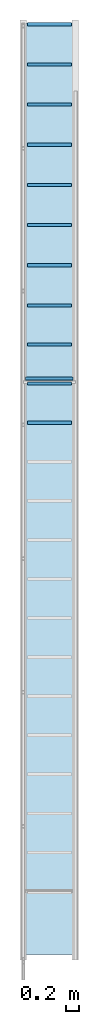
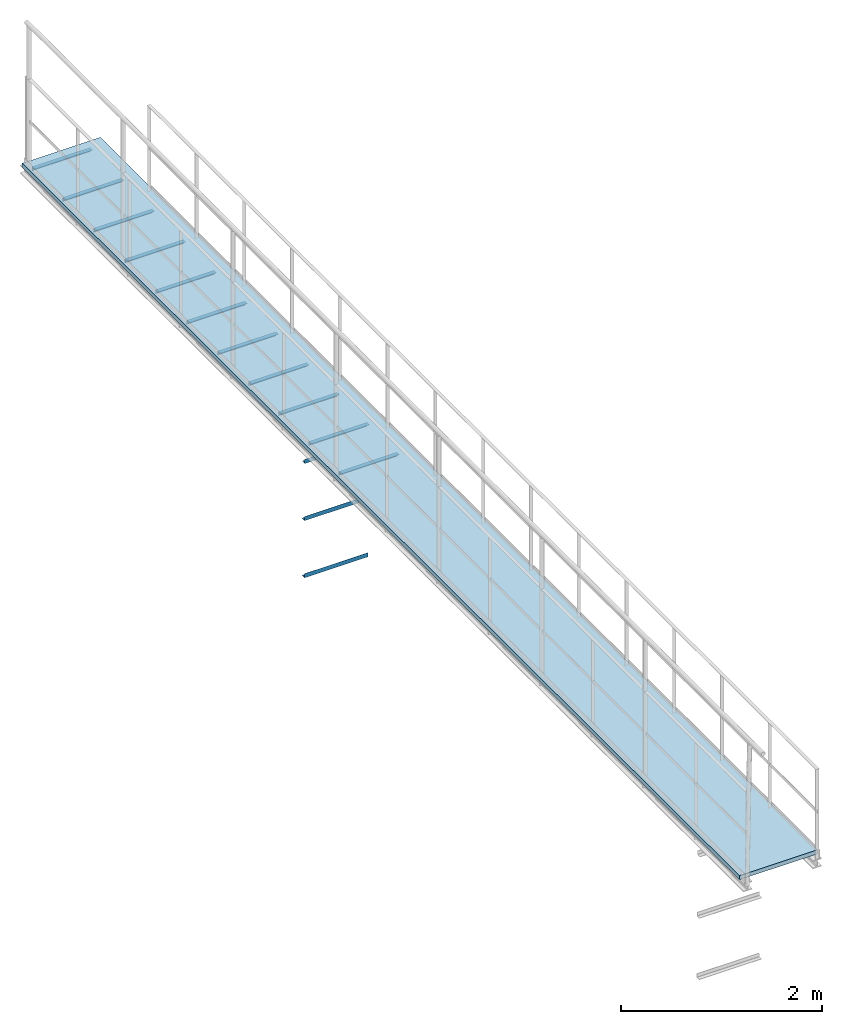
# One storey, part 5 of 6: 11 beams, 3 members, 1 slab.
"""IFC2X3 building model written with IfcOpenShell, lengths in metres."""

from ifc_helpers import new_model, entity, si_unit, converted_unit, derived_unit, direction, frame, frame_2d, origin, place, context, subcontext, project, spatial, polyline, circle_curve, parameter, trimmed, segment, composite_curve, rectangle, outline, extrude, source, transform, mapped, material, layer, layer_set, layer_usage, type_object, type_shapes, element, save


model = new_model("IFC2X3")

# Units and contexts
model_context = context("Model", 3, precision=1e-05, world=origin(), true_north=direction((6.123233995736766e-17, 1.0)))
body_context = subcontext(model_context, "Body", "Model", "MODEL_VIEW")
ifc_project = project(units=[si_unit("LENGTHUNIT", "METRE"), converted_unit("PLANEANGLEUNIT", "DEGREE", entity("IfcPlaneAngleMeasure", 0.017453292519943278), si_unit("PLANEANGLEUNIT", "RADIAN"), dimensions=[0, 0, 0, 0, 0, 0, 0]), si_unit("AREAUNIT", "SQUARE_METRE"), derived_unit("THERMALTRANSMITTANCEUNIT", [(si_unit("MASSUNIT", "GRAM", prefix="KILO"), 1), (si_unit("THERMODYNAMICTEMPERATUREUNIT", "KELVIN"), -1), (si_unit("TIMEUNIT", "SECOND"), -3)])], contexts=[model_context])

# Site, building, storey
site_placement = place(None, origin())
site = spatial("IfcSite", under=ifc_project, at=site_placement, CompositionType="ELEMENT")
building_placement = place(site_placement, origin())
building = spatial("IfcBuilding", under=site, at=building_placement, CompositionType="ELEMENT")
storey_placement = place(building_placement, frame((0.0, 0.0, 8.8)))
storey = spatial("IfcBuildingStorey", under=building, at=storey_placement, Name="Piso 2.3", CompositionType="ELEMENT", Elevation=8.8)

# Beams
ifc_material_1 = material(Name="Metal - Steel - 345 MPa")
beam_type = type_object("IfcBeamType", Name="L-Angles:CAE50x5", PredefinedType="BEAM")
beam_1_placement = place(storey_placement, frame((3.7066971351921265, 3.8935222324362275, 0.0)))
element("IfcBeam", 1, at=beam_1_placement, inside=storey, type_object=beam_type, material=ifc_material_1, Name="L-Angles:CAE50x5", ObjectType="L-Angles:CAE50x5", context=body_context, shape_type="SweptSolid", body=[
    extrude(outline(composite_curve([segment(polyline([(-0.033571428571429786, -0.01642857142857166), (0.016428571428569683, -0.01642857142857166)]), True, "CONTINUOUS"), segment(polyline([(0.016428571428569683, -0.0164285714285722), (0.016428571428570224, 0.03357142857143051)]), True, "CONTINUOUS"), segment(trimmed(circle_curve(frame_2d((0.01642857142857017, 0.02857142857143002), x_axis=(0.0, 1.0)), 0.004999999999999386), [parameter(0.0)], [parameter(90.0000000000187)], True, "PARAMETER"), True, "CONTINUOUS"), segment(polyline([(0.011428571428571305, 0.02857142857142953), (0.011428571428570927, -0.006428571428572257)]), True, "CONTINUOUS"), segment(trimmed(circle_curve(frame_2d((0.00642857142857098, -0.006428571428572743), x_axis=(1.0, 0.0)), 0.004999999999999392), [parameter(269.9999999999813)], [parameter(0.0)], True, "PARAMETER"), False, "CONTINUOUS"), segment(polyline([(0.006428571428569843, -0.011428571428572148), (-0.028571428571430864, -0.011428571428571229)]), True, "CONTINUOUS"), segment(trimmed(circle_curve(frame_2d((-0.028571428571429833, -0.016428571428571716), x_axis=(0.0, 1.0)), 0.0049999999999998075), [parameter(0.0)], [parameter(90.00000000000009)], True, "PARAMETER"), True, "CONTINUOUS")], self_intersect=False)), frame((0.06300000000002287, -0.002428571428571418, -0.002428571428575208), z_axis=(1.0, 0.0, 0.0), x_axis=(0.0, 0.0, 1.0)), (0.0, 0.0, 1.0), 0.6740000000000007),
])
beam_2_placement = place(storey_placement, frame((3.7066971351921265, 4.493522232436228, 0.0)))
element("IfcBeam", 2, at=beam_2_placement, inside=storey, type_object=beam_type, material=ifc_material_1, Name="L-Angles:CAE50x5", ObjectType="L-Angles:CAE50x5", context=body_context, shape_type="SweptSolid", body=[
    extrude(outline(composite_curve([segment(polyline([(-0.033571428571429786, -0.01642857142857112), (0.016428571428569683, -0.01642857142857112)]), True, "CONTINUOUS"), segment(polyline([(0.016428571428569683, -0.01642857142857166), (0.016428571428570224, 0.03357142857143105)]), True, "CONTINUOUS"), segment(trimmed(circle_curve(frame_2d((0.01642857142857017, 0.028571428571430562), x_axis=(0.0, 1.0)), 0.004999999999999386), [parameter(0.0)], [parameter(90.0000000000187)], True, "PARAMETER"), True, "CONTINUOUS"), segment(polyline([(0.011428571428571305, 0.028571428571430073), (0.011428571428570927, -0.006428571428571715)]), True, "CONTINUOUS"), segment(trimmed(circle_curve(frame_2d((0.00642857142857098, -0.006428571428572201), x_axis=(1.0, 0.0)), 0.004999999999999392), [parameter(269.9999999999813)], [parameter(0.0)], True, "PARAMETER"), False, "CONTINUOUS"), segment(polyline([(0.006428571428569843, -0.011428571428571607), (-0.028571428571430864, -0.011428571428570686)]), True, "CONTINUOUS"), segment(trimmed(circle_curve(frame_2d((-0.028571428571429833, -0.016428571428571175), x_axis=(0.0, 1.0)), 0.0049999999999998075), [parameter(0.0)], [parameter(90.00000000000009)], True, "PARAMETER"), True, "CONTINUOUS")], self_intersect=False)), frame((0.06300000000002301, -0.0024285714285708763, -0.002428571428575208), z_axis=(1.0, 0.0, 0.0), x_axis=(0.0, 0.0, 1.0)), (0.0, 0.0, 1.0), 0.6740000000000007),
])
beam_3_placement = place(storey_placement, frame((3.7066971351921265, 5.093522232436227, 0.0)))
element("IfcBeam", 3, at=beam_3_placement, inside=storey, type_object=beam_type, material=ifc_material_1, Name="L-Angles:CAE50x5", ObjectType="L-Angles:CAE50x5", context=body_context, shape_type="SweptSolid", body=[
    extrude(outline(composite_curve([segment(polyline([(-0.033571428571429605, -0.016428571428572025), (0.01642857142856986, -0.016428571428572025)]), True, "CONTINUOUS"), segment(polyline([(0.01642857142856986, -0.016428571428572025), (0.01642857142856986, 0.033571428571429605)]), True, "CONTINUOUS"), segment(trimmed(circle_curve(frame_2d((0.01642857142856986, 0.02857142857143182), x_axis=(0.0, 1.0)), 0.004999999999999224), [parameter(0.0)], [parameter(90.00000000002491)], True, "PARAMETER"), True, "CONTINUOUS"), segment(polyline([(0.011428571428570997, 0.02857142857143074), (0.011428571428570997, -0.00642857142857105)]), True, "CONTINUOUS"), segment(trimmed(circle_curve(frame_2d((0.006428571428571049, -0.006428571428573215), x_axis=(1.0, 0.0)), 0.004999999999999229), [parameter(269.9999999999751)], [parameter(0.0)], True, "PARAMETER"), False, "CONTINUOUS"), segment(polyline([(0.006428571428569967, -0.011428571428572079), (-0.02857142857143074, -0.011428571428572079)]), True, "CONTINUOUS"), segment(trimmed(circle_curve(frame_2d((-0.028571428571429656, -0.016428571428572025), x_axis=(0.0, 1.0)), 0.004999999999999669), [parameter(0.0)], [parameter(90.00000000000009)], True, "PARAMETER"), True, "CONTINUOUS")], self_intersect=False)), frame((0.06300000000002313, -0.002428571428571959, -0.002428571428575208), z_axis=(1.0, 0.0, 0.0), x_axis=(0.0, 0.0, 1.0)), (0.0, 0.0, 1.0), 0.6740000000000007),
])
beam_4_placement = place(storey_placement, frame((3.7066971351921265, 5.693522232436227, 0.0)))
element("IfcBeam", 4, at=beam_4_placement, inside=storey, type_object=beam_type, material=ifc_material_1, Name="L-Angles:CAE50x5", ObjectType="L-Angles:CAE50x5", context=body_context, shape_type="SweptSolid", body=[
    extrude(outline(composite_curve([segment(polyline([(-0.033571428571429605, -0.016428571428572025), (0.01642857142856986, -0.016428571428572025)]), True, "CONTINUOUS"), segment(polyline([(0.01642857142856986, -0.016428571428572025), (0.01642857142856986, 0.033571428571429605)]), True, "CONTINUOUS"), segment(trimmed(circle_curve(frame_2d((0.01642857142856986, 0.02857142857143182), x_axis=(0.0, 1.0)), 0.004999999999999224), [parameter(0.0)], [parameter(90.00000000002491)], True, "PARAMETER"), True, "CONTINUOUS"), segment(polyline([(0.011428571428570997, 0.02857142857143074), (0.011428571428570997, -0.00642857142857105)]), True, "CONTINUOUS"), segment(trimmed(circle_curve(frame_2d((0.006428571428571049, -0.006428571428573215), x_axis=(1.0, 0.0)), 0.004999999999999229), [parameter(269.9999999999751)], [parameter(0.0)], True, "PARAMETER"), False, "CONTINUOUS"), segment(polyline([(0.006428571428569967, -0.011428571428572079), (-0.02857142857143074, -0.011428571428572079)]), True, "CONTINUOUS"), segment(trimmed(circle_curve(frame_2d((-0.028571428571429656, -0.016428571428572025), x_axis=(0.0, 1.0)), 0.004999999999999669), [parameter(0.0)], [parameter(90.00000000000009)], True, "PARAMETER"), True, "CONTINUOUS")], self_intersect=False)), frame((0.06300000000002327, -0.002428571428571959, -0.002428571428575208), z_axis=(1.0, 0.0, 0.0), x_axis=(0.0, 0.0, 1.0)), (0.0, 0.0, 1.0), 0.6740000000000007),
])
beam_5_placement = place(storey_placement, frame((3.7066971351921336, 10.011170093366113, 0.0)))
element("IfcBeam", 5, at=beam_5_placement, inside=storey, type_object=beam_type, material=ifc_material_1, Name="L-Angles:CAE50x5", ObjectType="L-Angles:CAE50x5", context=body_context, shape_type="SweptSolid", body=[
    extrude(outline(composite_curve([segment(polyline([(-0.033571428571429605, -0.016428571428572025), (0.01642857142856986, -0.016428571428572025)]), True, "CONTINUOUS"), segment(polyline([(0.01642857142856986, -0.016428571428572025), (0.01642857142856986, 0.033571428571429605)]), True, "CONTINUOUS"), segment(trimmed(circle_curve(frame_2d((0.016428571428573107, 0.02857142857142641), x_axis=(0.0, 1.0)), 0.00500000000000243), [parameter(0.0)], [parameter(89.99999999995046)], True, "PARAMETER"), True, "CONTINUOUS"), segment(polyline([(0.011428571428570997, 0.028571428571428574), (0.011428571428570997, -0.0064285714285742986)]), True, "CONTINUOUS"), segment(trimmed(circle_curve(frame_2d((0.006428571428567802, -0.006428571428569967), x_axis=(1.0, 0.0)), 0.005000000000002431), [parameter(270.0000000000495)], [parameter(0.0)], True, "PARAMETER"), False, "CONTINUOUS"), segment(polyline([(0.006428571428569967, -0.011428571428573162), (-0.02857142857143074, -0.011428571428573162)]), True, "CONTINUOUS"), segment(trimmed(circle_curve(frame_2d((-0.02857142857142749, -0.016428571428574193), x_axis=(0.0, 1.0)), 0.005000000000002427), [parameter(0.0)], [parameter(89.99999999995046)], True, "PARAMETER"), True, "CONTINUOUS")], self_intersect=False)), frame((0.06300000000002329, -0.002428571428575208, -0.002428571428575208), z_axis=(1.0, 0.0, 0.0), x_axis=(0.0, 0.0, 1.0)), (0.0, 0.0, 1.0), 0.6740000000000002),
])
beam_6_placement = place(storey_placement, frame((3.7066971351921265, 6.310329069711925, 0.0)))
element("IfcBeam", 6, at=beam_6_placement, inside=storey, type_object=beam_type, material=ifc_material_1, Name="L-Angles:CAE50x5", ObjectType="L-Angles:CAE50x5", context=body_context, shape_type="SweptSolid", body=[
    extrude(outline(composite_curve([segment(polyline([(-0.033571428571429605, -0.016428571428572025), (0.01642857142856986, -0.016428571428572025)]), True, "CONTINUOUS"), segment(polyline([(0.01642857142856986, -0.016428571428572025), (0.01642857142856986, 0.033571428571429605)]), True, "CONTINUOUS"), segment(trimmed(circle_curve(frame_2d((0.01642857142856986, 0.02857142857143182), x_axis=(0.0, 1.0)), 0.004999999999999224), [parameter(0.0)], [parameter(90.00000000002491)], True, "PARAMETER"), True, "CONTINUOUS"), segment(polyline([(0.011428571428570997, 0.02857142857143074), (0.011428571428570997, -0.00642857142857105)]), True, "CONTINUOUS"), segment(trimmed(circle_curve(frame_2d((0.006428571428571049, -0.006428571428573215), x_axis=(1.0, 0.0)), 0.004999999999999229), [parameter(269.9999999999751)], [parameter(0.0)], True, "PARAMETER"), False, "CONTINUOUS"), segment(polyline([(0.006428571428569967, -0.011428571428572079), (-0.02857142857143074, -0.011428571428572079)]), True, "CONTINUOUS"), segment(trimmed(circle_curve(frame_2d((-0.028571428571429656, -0.016428571428572025), x_axis=(0.0, 1.0)), 0.004999999999999669), [parameter(0.0)], [parameter(90.00000000000009)], True, "PARAMETER"), True, "CONTINUOUS")], self_intersect=False)), frame((0.06300000000002282, -0.002428571428571959, -0.002428571428575208), z_axis=(1.0, 0.0, 0.0), x_axis=(0.0, 0.0, 1.0)), (0.0, 0.0, 1.0), 0.6740000000000007),
])
beam_7_placement = place(storey_placement, frame((3.7066971351921265, 6.9271359069876235, 0.0)))
element("IfcBeam", 7, at=beam_7_placement, inside=storey, type_object=beam_type, material=ifc_material_1, Name="L-Angles:CAE50x5", ObjectType="L-Angles:CAE50x5", context=body_context, shape_type="SweptSolid", body=[
    extrude(outline(composite_curve([segment(polyline([(-0.033571428571429605, -0.016428571428572025), (0.01642857142856986, -0.016428571428572025)]), True, "CONTINUOUS"), segment(polyline([(0.01642857142856986, -0.016428571428572025), (0.01642857142856986, 0.033571428571429605)]), True, "CONTINUOUS"), segment(trimmed(circle_curve(frame_2d((0.01642857142856986, 0.02857142857143182), x_axis=(0.0, 1.0)), 0.004999999999999224), [parameter(0.0)], [parameter(90.00000000002491)], True, "PARAMETER"), True, "CONTINUOUS"), segment(polyline([(0.011428571428570997, 0.02857142857143074), (0.011428571428570997, -0.00642857142857105)]), True, "CONTINUOUS"), segment(trimmed(circle_curve(frame_2d((0.006428571428571049, -0.006428571428573215), x_axis=(1.0, 0.0)), 0.004999999999999229), [parameter(269.9999999999751)], [parameter(0.0)], True, "PARAMETER"), False, "CONTINUOUS"), segment(polyline([(0.006428571428569967, -0.011428571428572079), (-0.02857142857143074, -0.011428571428572079)]), True, "CONTINUOUS"), segment(trimmed(circle_curve(frame_2d((-0.028571428571429656, -0.016428571428572025), x_axis=(0.0, 1.0)), 0.004999999999999669), [parameter(0.0)], [parameter(90.00000000000009)], True, "PARAMETER"), True, "CONTINUOUS")], self_intersect=False)), frame((0.06300000000002288, -0.002428571428571959, -0.002428571428575208), z_axis=(1.0, 0.0, 0.0), x_axis=(0.0, 0.0, 1.0)), (0.0, 0.0, 1.0), 0.6740000000000007),
])
beam_8_placement = place(storey_placement, frame((3.7066971351921265, 7.543942744263322, 0.0)))
element("IfcBeam", 8, at=beam_8_placement, inside=storey, type_object=beam_type, material=ifc_material_1, Name="L-Angles:CAE50x5", ObjectType="L-Angles:CAE50x5", context=body_context, shape_type="SweptSolid", body=[
    extrude(outline(composite_curve([segment(polyline([(-0.033571428571429605, -0.016428571428572025), (0.01642857142856986, -0.016428571428572025)]), True, "CONTINUOUS"), segment(polyline([(0.01642857142856986, -0.016428571428572025), (0.01642857142856986, 0.033571428571429605)]), True, "CONTINUOUS"), segment(trimmed(circle_curve(frame_2d((0.01642857142856986, 0.02857142857143182), x_axis=(0.0, 1.0)), 0.004999999999999224), [parameter(0.0)], [parameter(90.00000000002491)], True, "PARAMETER"), True, "CONTINUOUS"), segment(polyline([(0.011428571428570997, 0.02857142857143074), (0.011428571428570997, -0.00642857142857105)]), True, "CONTINUOUS"), segment(trimmed(circle_curve(frame_2d((0.006428571428571049, -0.006428571428573215), x_axis=(1.0, 0.0)), 0.004999999999999229), [parameter(269.9999999999751)], [parameter(0.0)], True, "PARAMETER"), False, "CONTINUOUS"), segment(polyline([(0.006428571428569967, -0.011428571428572079), (-0.02857142857143074, -0.011428571428572079)]), True, "CONTINUOUS"), segment(trimmed(circle_curve(frame_2d((-0.028571428571429656, -0.016428571428572025), x_axis=(0.0, 1.0)), 0.004999999999999669), [parameter(0.0)], [parameter(90.00000000000009)], True, "PARAMETER"), True, "CONTINUOUS")], self_intersect=False)), frame((0.06300000000002297, -0.002428571428571959, -0.002428571428575208), z_axis=(1.0, 0.0, 0.0), x_axis=(0.0, 0.0, 1.0)), (0.0, 0.0, 1.0), 0.6740000000000007),
])
beam_9_placement = place(storey_placement, frame((3.7066971351921265, 8.160749581539019, 0.0)))
element("IfcBeam", 9, at=beam_9_placement, inside=storey, type_object=beam_type, material=ifc_material_1, Name="L-Angles:CAE50x5", ObjectType="L-Angles:CAE50x5", context=body_context, shape_type="SweptSolid", body=[
    extrude(outline(composite_curve([segment(polyline([(-0.033571428571429605, -0.016428571428573107), (0.01642857142856986, -0.016428571428573107)]), True, "CONTINUOUS"), segment(polyline([(0.01642857142856986, -0.016428571428573107), (0.01642857142856986, 0.03357142857142852)]), True, "CONTINUOUS"), segment(trimmed(circle_curve(frame_2d((0.01642857142856986, 0.02857142857143074), x_axis=(0.0, 1.0)), 0.004999999999999224), [parameter(0.0)], [parameter(90.00000000002491)], True, "PARAMETER"), True, "CONTINUOUS"), segment(polyline([(0.011428571428570997, 0.028571428571429656), (0.011428571428570997, -0.006428571428572134)]), True, "CONTINUOUS"), segment(trimmed(circle_curve(frame_2d((0.006428571428571049, -0.0064285714285742986), x_axis=(1.0, 0.0)), 0.004999999999999229), [parameter(269.9999999999751)], [parameter(0.0)], True, "PARAMETER"), False, "CONTINUOUS"), segment(polyline([(0.006428571428569967, -0.011428571428573162), (-0.02857142857143074, -0.011428571428573162)]), True, "CONTINUOUS"), segment(trimmed(circle_curve(frame_2d((-0.028571428571429656, -0.016428571428573107), x_axis=(0.0, 1.0)), 0.004999999999999669), [parameter(0.0)], [parameter(90.00000000000009)], True, "PARAMETER"), True, "CONTINUOUS")], self_intersect=False)), frame((0.06300000000002305, -0.002428571428573042, -0.002428571428575208), z_axis=(1.0, 0.0, 0.0), x_axis=(0.0, 0.0, 1.0)), (0.0, 0.0, 1.0), 0.6740000000000007),
])
beam_10_placement = place(storey_placement, frame((3.7066971351921265, 8.777556418814719, 0.0)))
element("IfcBeam", 10, at=beam_10_placement, inside=storey, type_object=beam_type, material=ifc_material_1, Name="L-Angles:CAE50x5", ObjectType="L-Angles:CAE50x5", context=body_context, shape_type="SweptSolid", body=[
    extrude(outline(composite_curve([segment(polyline([(-0.033571428571429605, -0.016428571428573107), (0.01642857142856986, -0.016428571428573107)]), True, "CONTINUOUS"), segment(polyline([(0.01642857142856986, -0.016428571428573107), (0.01642857142856986, 0.03357142857142852)]), True, "CONTINUOUS"), segment(trimmed(circle_curve(frame_2d((0.01642857142856986, 0.02857142857143074), x_axis=(0.0, 1.0)), 0.004999999999999224), [parameter(0.0)], [parameter(90.00000000002491)], True, "PARAMETER"), True, "CONTINUOUS"), segment(polyline([(0.011428571428570997, 0.028571428571429656), (0.011428571428570997, -0.006428571428572134)]), True, "CONTINUOUS"), segment(trimmed(circle_curve(frame_2d((0.006428571428571049, -0.0064285714285742986), x_axis=(1.0, 0.0)), 0.004999999999999229), [parameter(269.9999999999751)], [parameter(0.0)], True, "PARAMETER"), False, "CONTINUOUS"), segment(polyline([(0.006428571428569967, -0.011428571428573162), (-0.02857142857143074, -0.011428571428573162)]), True, "CONTINUOUS"), segment(trimmed(circle_curve(frame_2d((-0.028571428571429656, -0.016428571428573107), x_axis=(0.0, 1.0)), 0.004999999999999669), [parameter(0.0)], [parameter(90.00000000000009)], True, "PARAMETER"), True, "CONTINUOUS")], self_intersect=False)), frame((0.06300000000002312, -0.002428571428573042, -0.002428571428575208), z_axis=(1.0, 0.0, 0.0), x_axis=(0.0, 0.0, 1.0)), (0.0, 0.0, 1.0), 0.6740000000000007),
])
beam_11_placement = place(storey_placement, frame((3.7066971351921265, 9.394363256090417, 0.0)))
element("IfcBeam", 11, at=beam_11_placement, inside=storey, type_object=beam_type, material=ifc_material_1, Name="L-Angles:CAE50x5", ObjectType="L-Angles:CAE50x5", context=body_context, shape_type="SweptSolid", body=[
    extrude(outline(composite_curve([segment(polyline([(-0.033571428571429605, -0.016428571428573107), (0.01642857142856986, -0.016428571428573107)]), True, "CONTINUOUS"), segment(polyline([(0.01642857142856986, -0.016428571428573107), (0.01642857142856986, 0.03357142857142852)]), True, "CONTINUOUS"), segment(trimmed(circle_curve(frame_2d((0.01642857142856986, 0.02857142857143074), x_axis=(0.0, 1.0)), 0.004999999999999224), [parameter(0.0)], [parameter(90.00000000002491)], True, "PARAMETER"), True, "CONTINUOUS"), segment(polyline([(0.011428571428570997, 0.028571428571429656), (0.011428571428570997, -0.006428571428572134)]), True, "CONTINUOUS"), segment(trimmed(circle_curve(frame_2d((0.006428571428571049, -0.0064285714285742986), x_axis=(1.0, 0.0)), 0.004999999999999229), [parameter(269.9999999999751)], [parameter(0.0)], True, "PARAMETER"), False, "CONTINUOUS"), segment(polyline([(0.006428571428569967, -0.011428571428573162), (-0.02857142857143074, -0.011428571428573162)]), True, "CONTINUOUS"), segment(trimmed(circle_curve(frame_2d((-0.028571428571429656, -0.016428571428573107), x_axis=(0.0, 1.0)), 0.004999999999999669), [parameter(0.0)], [parameter(90.00000000000009)], True, "PARAMETER"), True, "CONTINUOUS")], self_intersect=False)), frame((0.0630000000000232, -0.002428571428573042, -0.002428571428575208), z_axis=(1.0, 0.0, 0.0), x_axis=(0.0, 0.0, 1.0)), (0.0, 0.0, 1.0), 0.6740000000000007),
])

# Members
member_type = type_object("IfcMemberType", Name="L-Angles:CAE50x5", PredefinedType="BRACE", material=ifc_material_1)
shared_shape = source(origin(), body_context, "Body", "SweptSolid", [
    extrude(outline(composite_curve([segment(polyline([(-0.016428571428572104, -0.016428571428570952), (0.03357142857143008, -0.016428571428570952)]), True, "CONTINUOUS"), segment(trimmed(circle_curve(frame_2d((0.02857142857143008, -0.016428571428571702), x_axis=(1.0, 0.0)), 0.005), [parameter(5.088887490341632e-14)], [parameter(90.00000000000009)], True, "PARAMETER"), True, "CONTINUOUS"), segment(polyline([(0.02857142857143009, -0.011428571428571706), (-0.006428571428571976, -0.011428571428571706)]), True, "CONTINUOUS"), segment(trimmed(circle_curve(frame_2d((-0.006428571428571986, -0.006428571428571703), x_axis=(1.0, 0.0)), 0.005), [parameter(180.00000000000017)], [parameter(269.9999999999999)], True, "PARAMETER"), False, "CONTINUOUS"), segment(polyline([(-0.011428571428571985, -0.006428571428571719), (-0.011428571428571985, 0.02857142857142889)]), True, "CONTINUOUS"), segment(trimmed(circle_curve(frame_2d((-0.016428571428571986, 0.02857142857142889), x_axis=(1.0, 0.0)), 0.005), [parameter(0.0)], [parameter(90.00000000000024)], True, "PARAMETER"), True, "CONTINUOUS"), segment(polyline([(-0.016428571428572104, 0.03357142857142889), (-0.016428571428572104, -0.01642857142857095)]), True, "CONTINUOUS")], self_intersect=False)), frame((-0.36499999999999994, -0.0024285714285723395, -0.0024285714285764517), z_axis=(1.0, 0.0, 0.0), x_axis=(0.0, -1.0, 0.0)), (0.0, 0.0, 1.0), 0.73),
])
type_shapes(member_type, [shared_shape])
for number, where, z_axis, x_axis, name in (
    (12, (4.106697135192162, 4.5475222324362266, -0.2459999999999993), (0.0, -1.0, 0.0), (-1.0, 0.0, 0.0), "L-Angles:CAE50x5"),
    (13, (4.106697135192149, 4.5475222324362266, -1.6359999999999995), (0.0, -1.0, 0.0), (-1.0, 0.0, 0.0), "L-Angles:CAE50x5"),
    (14, (4.106697135192149, 4.5475222324362266, -0.9409999999999994), (0.0, -1.0, 0.0), (-1.0, 0.0, 0.0), "L-Angles:CAE50x5"),
):
    element("IfcMember", number, at=place(storey_placement, frame(where, z_axis=z_axis, x_axis=x_axis)), inside=storey, type_object=member_type, material=ifc_material_1, Name=name, ObjectType="L-Angles:CAE50x5", context=body_context, shape_type="MappedRepresentation", body=[
        mapped(shared_shape, transform((0.0, 0.0, 0.0), scale=1.0)),
    ])

# Slab
ifc_material_2 = material(Name="C25/30")
ifc_layer = layer(ifc_material_2, 0.05)
ifc_layer_set = layer_set([ifc_layer], Name="Floor:50mm")
ifc_layer_usage = layer_usage(ifc_layer_set, "AXIS3", "POSITIVE", 0.0)
slab_type = type_object("IfcSlabType", Name="Floor:50mm", PredefinedType="FLOOR", material=ifc_layer_set)
slab_placement = place(storey_placement, origin())
element("IfcSlab", 15, at=slab_placement, inside=storey, type_object=slab_type, material=ifc_layer_usage, Name="Floor:50mm", ObjectType="Floor:50mm", PredefinedType="FLOOR", context=body_context, shape_type="SweptSolid", body=[
    extrude(rectangle(XDim=14.3044419633786, YDim=0.9000000000000645, at=frame_2d((0.0, -2.7755575615628914e-16), x_axis=(1.0, 0.0))), frame((4.106697135192158, 2.8679491116768134, 0.09999999999999892), z_axis=(0.0, 0.0, -1.0), x_axis=(0.0, 1.0, 0.0)), (0.0, 0.0, 1.0), 0.04999999999999946),
])

save(model, "model.ifc")
